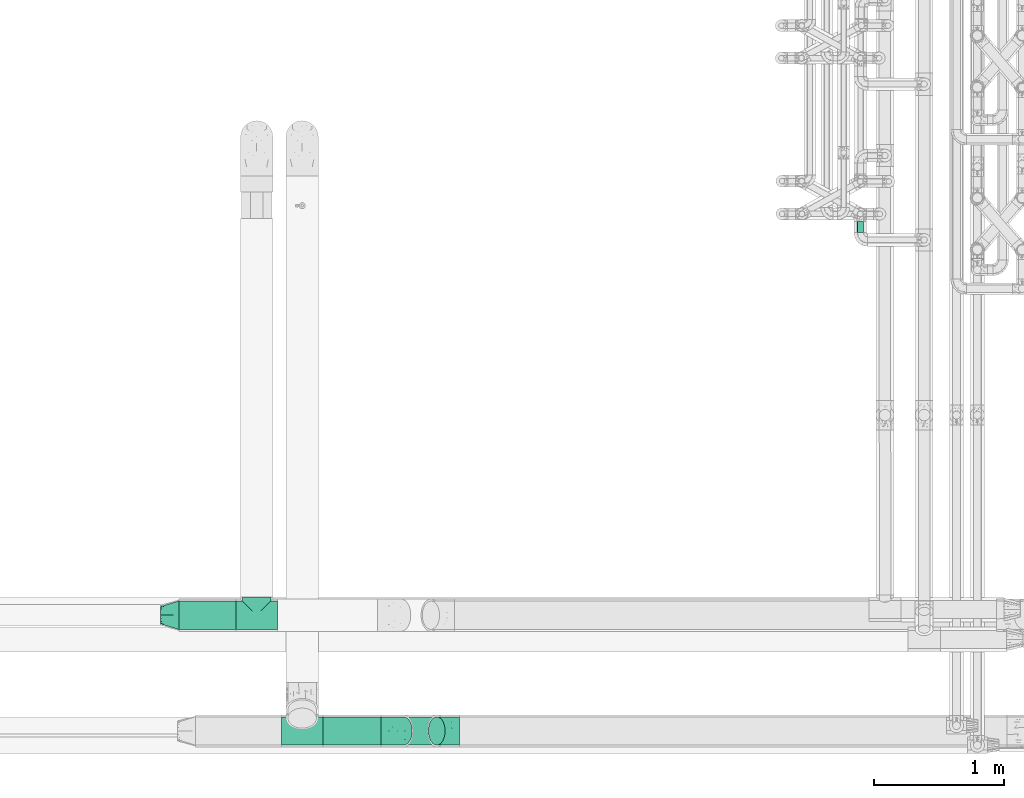
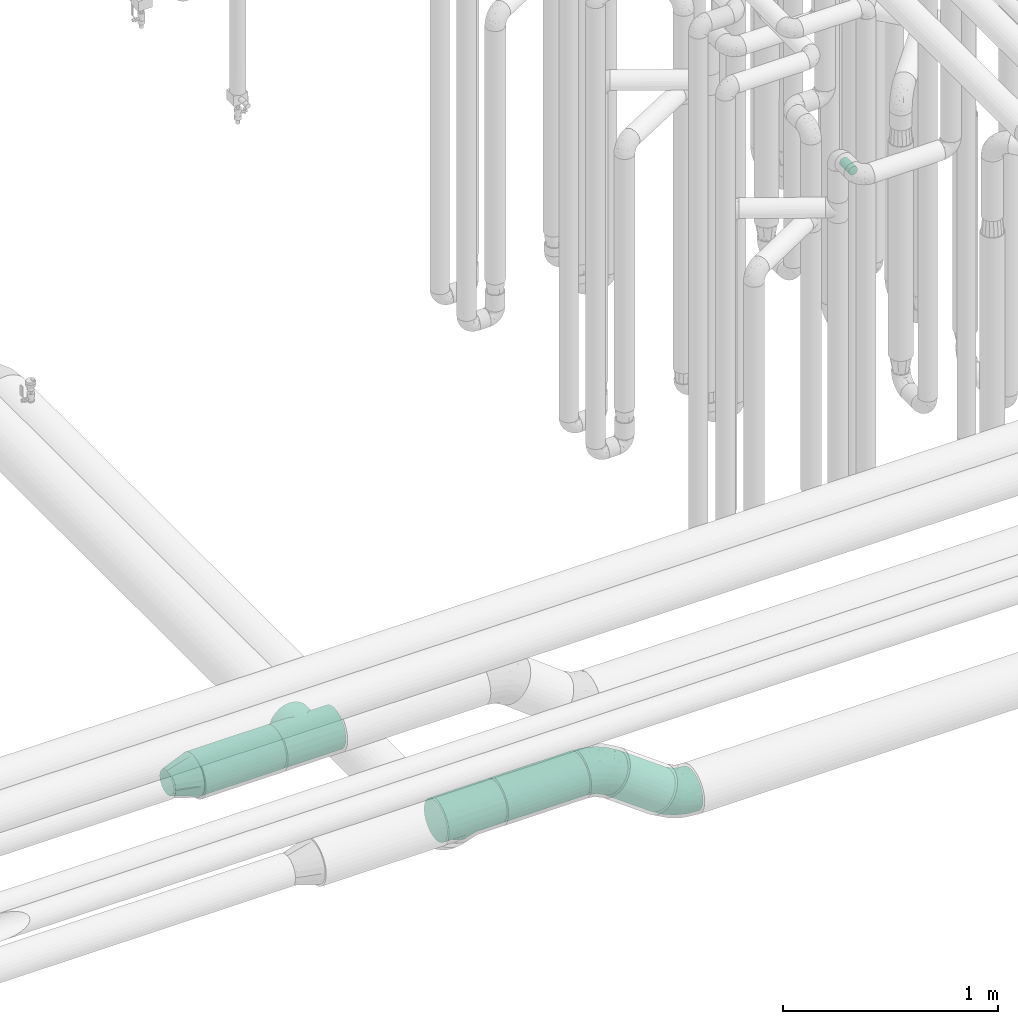
# One storey, part 594 of 824: 5 flow fittings, 4 flow segments.
"""IFC2X3 building model written with IfcOpenShell, lengths in millimetres."""

from ifc_helpers import new_model, entity, si_unit, converted_unit, derived_unit, direction, frame, origin, origin_2d_with_axis, place, context, subcontext, project, spatial, circle, extrude, faceted_brep, source, transform, mapped, material, type_object, type_shapes, element, save


model = new_model("IFC2X3")

# Units and contexts
model_context = context("Model", 3, precision=0.01, world=origin(), true_north=direction((6.12303176911189e-17, 1.0)))
body_context = subcontext(model_context, "Body", "Model", "MODEL_VIEW")
ifc_project = project(units=[si_unit("LENGTHUNIT", "METRE", prefix="MILLI"), si_unit("AREAUNIT", "SQUARE_METRE"), si_unit("VOLUMEUNIT", "CUBIC_METRE"), converted_unit("PLANEANGLEUNIT", "DEGREE", entity("IfcRatioMeasure", 0.0174532925199433), si_unit("PLANEANGLEUNIT", "RADIAN"), dimensions=[0, 0, 0, 0, 0, 0, 0]), si_unit("MASSUNIT", "GRAM", prefix="KILO"), derived_unit("MASSDENSITYUNIT", [(si_unit("MASSUNIT", "GRAM", prefix="KILO"), 1), (si_unit("LENGTHUNIT", "METRE"), -3)]), derived_unit("MOMENTOFINERTIAUNIT", [(si_unit("LENGTHUNIT", "METRE"), 4)]), si_unit("TIMEUNIT", "SECOND"), si_unit("FREQUENCYUNIT", "HERTZ"), si_unit("THERMODYNAMICTEMPERATUREUNIT", "DEGREE_CELSIUS"), derived_unit("THERMALTRANSMITTANCEUNIT", [(si_unit("MASSUNIT", "GRAM", prefix="KILO"), 1), (si_unit("THERMODYNAMICTEMPERATUREUNIT", "KELVIN"), -1), (si_unit("TIMEUNIT", "SECOND"), -3)]), derived_unit("VOLUMETRICFLOWRATEUNIT", [(si_unit("LENGTHUNIT", "METRE"), 3), (si_unit("TIMEUNIT", "SECOND"), -1)]), derived_unit("MASSFLOWRATEUNIT", [(si_unit("MASSUNIT", "GRAM", prefix="KILO"), 1), (si_unit("TIMEUNIT", "SECOND"), -1)]), derived_unit("ROTATIONALFREQUENCYUNIT", [(si_unit("TIMEUNIT", "SECOND"), -1)]), si_unit("ELECTRICCURRENTUNIT", "AMPERE"), si_unit("ELECTRICVOLTAGEUNIT", "VOLT"), si_unit("POWERUNIT", "WATT"), si_unit("FORCEUNIT", "NEWTON", prefix="KILO"), si_unit("ILLUMINANCEUNIT", "LUX"), si_unit("LUMINOUSFLUXUNIT", "LUMEN"), si_unit("LUMINOUSINTENSITYUNIT", "CANDELA"), derived_unit("USERDEFINED", [(si_unit("MASSUNIT", "GRAM", prefix="KILO"), -1), (si_unit("LENGTHUNIT", "METRE"), -2), (si_unit("TIMEUNIT", "SECOND"), 3), (si_unit("LUMINOUSFLUXUNIT", "LUMEN"), 1)]), derived_unit("LINEARVELOCITYUNIT", [(si_unit("LENGTHUNIT", "METRE"), 1), (si_unit("TIMEUNIT", "SECOND"), -1)]), si_unit("PRESSUREUNIT", "PASCAL"), derived_unit("USERDEFINED", [(si_unit("LENGTHUNIT", "METRE"), -2), (si_unit("MASSUNIT", "GRAM", prefix="KILO"), 1), (si_unit("TIMEUNIT", "SECOND"), -2)]), derived_unit("LINEARFORCEUNIT", [(si_unit("MASSUNIT", "GRAM", prefix="KILO"), 1), (si_unit("LENGTHUNIT", "METRE"), 1), (si_unit("TIMEUNIT", "SECOND"), -2), (si_unit("LENGTHUNIT", "METRE"), -1)]), derived_unit("PLANARFORCEUNIT", [(si_unit("MASSUNIT", "GRAM", prefix="KILO"), 1), (si_unit("LENGTHUNIT", "METRE"), 1), (si_unit("TIMEUNIT", "SECOND"), -2), (si_unit("LENGTHUNIT", "METRE"), -2)])], contexts=[model_context])

# Site, building, storey
site_placement = place(None, origin())
site = spatial("IfcSite", under=ifc_project, at=site_placement, CompositionType="ELEMENT")
building_placement = place(site_placement, origin())
building = spatial("IfcBuilding", under=site, at=building_placement, CompositionType="ELEMENT")
storey_placement = place(building_placement, frame((0.0, 0.0, 28200.0)))
storey = spatial("IfcBuildingStorey", under=building, at=storey_placement, CompositionType="ELEMENT", Elevation=28200.0)

# Flow segments
pipe_segment_type_1 = type_object("IfcPipeSegmentType", PredefinedType="NOTDEFINED")
flow_segment_1_placement = place(storey_placement, frame((30479.76, 7155.11, 2688.9)))
element("IfcFlowSegment", 1, at=flow_segment_1_placement, inside=storey, type_object=pipe_segment_type_1, context=body_context, shape_type="SweptSolid", body=[
    extrude(circle(Radius=109.5, at=origin_2d_with_axis()), frame((0.0, 111.1, 111.1), z_axis=(1.0, 0.0, 0.0), x_axis=(0.0, 1.0, 0.0)), (0.0, 0.0, 1.0), 440.240643085185),
])
flow_segment_2_placement = place(storey_placement, frame((31590.0, 6263.9, 2688.9)))
element("IfcFlowSegment", 2, at=flow_segment_2_placement, inside=storey, type_object=pipe_segment_type_1, context=body_context, shape_type="SweptSolid", body=[
    extrude(circle(Radius=109.5, at=origin_2d_with_axis()), frame((0.0, 111.1, 111.1), z_axis=(1.0, 0.0, 0.0), x_axis=(0.0, -1.0, 0.0)), (0.0, 0.0, 1.0), 446.080617390534),
])
flow_segment_3_placement = place(storey_placement, frame((32146.69, 6263.9, 2467.48)))
element("IfcFlowSegment", 3, at=flow_segment_3_placement, inside=storey, type_object=pipe_segment_type_1, context=body_context, shape_type="SweptSolid", body=[
    extrude(circle(Radius=109.5, at=origin_2d_with_axis()), frame((319.73, 111.1, 90.08), z_axis=(-0.80811788469918, 0.0, 0.589020784378041), x_axis=(0.0, -1.0, 0.0)), (0.0, 0.0, 1.0), 313.861133125843),
])
pipe_segment_type_2 = type_object("IfcPipeSegmentType", PredefinedType="NOTDEFINED")
flow_segment_4_placement = place(storey_placement, frame((35702.45, 10213.2, 2574.4)))
element("IfcFlowSegment", 4, at=flow_segment_4_placement, inside=storey, type_object=pipe_segment_type_2, context=body_context, shape_type="SweptSolid", body=[
    extrude(circle(Radius=24.0, at=origin_2d_with_axis()), frame((25.6, 0.0, 25.6), z_axis=(0.0, 1.0, 0.0), x_axis=(-1.0, 0.0, 0.0)), (0.0, 0.0, 1.0), 85.9654132835041),
])

# Flow fittings
ifc_material = material()
pipe_fitting_type_1 = type_object("IfcPipeFittingType", PredefinedType="NOTDEFINED", material=ifc_material)
shared_shape_1 = source(origin(), body_context, "Body", "Brep", [
    faceted_brep([(-160.0, 0.0, -109.5), (-160.0, -28.34, -105.77), (-160.0, -54.75, -94.83), (-160.0, -66.09, -86.13), (-160.0, -77.43, -77.43), (-160.0, -86.13, -66.09), (-160.0, -94.83, -54.75), (-160.0, -100.3, -41.55), (-160.0, -103.03, -34.94), (-160.0, -105.77, -28.34), (-160.0, -106.7, -21.26), (-160.0, -107.63, -14.17), (-160.0, -109.5, 0.0), (-160.0, -107.63, 14.17), (-160.0, -106.7, 21.26), (-160.0, -105.77, 28.34), (-160.0, -103.03, 34.94), (-160.0, -100.3, 41.55), (-160.0, -94.83, 54.75), (-160.0, -86.13, 66.09), (-160.0, -77.43, 77.43), (-160.0, -66.09, 86.13), (-160.0, -54.75, 94.83), (-160.0, -28.34, 105.77), (-160.0, 0.0, 109.5), (-160.0, 28.34, 105.77), (-160.0, 54.75, 94.83), (-160.0, 77.43, 77.43), (-160.0, 94.83, 54.75), (-160.0, 105.77, 28.34), (-160.0, 109.5, 0.0), (-160.0, 105.77, -28.34), (-160.0, 94.83, -54.75), (-160.0, 77.43, -77.43), (-160.0, 54.75, -94.83), (-160.0, 28.34, -105.77), (160.0, 28.34, -105.77), (160.0, 54.75, -94.83), (160.0, 77.43, -77.43), (160.0, 94.83, -54.75), (160.0, 105.77, -28.34), (160.0, 109.5, 0.0), (160.0, 105.77, 28.34), (160.0, 94.83, 54.75), (160.0, 77.43, 77.43), (160.0, 54.75, 94.83), (160.0, 28.34, 105.77), (160.0, 0.0, 109.5), (160.0, -28.34, 105.77), (160.0, -54.75, 94.83), (160.0, -66.09, 86.13), (160.0, -77.43, 77.43), (160.0, -86.13, 66.09), (160.0, -94.83, 54.75), (160.0, -100.3, 41.55), (160.0, -103.03, 34.94), (160.0, -105.77, 28.34), (160.0, -106.7, 21.26), (160.0, -107.63, 14.17), (160.0, -109.5, 0.0), (160.0, -107.63, -14.17), (160.0, -106.7, -21.26), (160.0, -105.77, -28.34), (160.0, -103.03, -34.94), (160.0, -100.3, -41.55), (160.0, -94.83, -54.75), (160.0, -86.13, -66.09), (160.0, -77.43, -77.43), (160.0, -66.09, -86.13), (160.0, -54.75, -94.83), (160.0, -28.34, -105.77), (160.0, 0.0, -109.5), (107.07, -107.07, 22.92), (108.29, -108.29, 11.46), (103.67, -103.67, 33.47), (100.26, -100.26, 44.01), (77.6, -77.6, 77.26), (63.52, -63.52, 89.2), (90.1, -90.1, 62.22), (95.18, -95.18, 53.12), (-100.26, -100.26, 44.01), (-103.67, -103.67, 33.47), (-108.29, -108.29, 11.46), (-107.07, -107.07, 22.92), (-109.5, -109.5, 0.0), (109.5, -109.5, 0.0), (-63.52, -63.52, 89.2), (-77.6, -77.6, 77.26), (-90.1, -90.1, 62.22), (-48.39, -48.39, 98.23), (-95.18, -95.18, 53.12), (48.39, -48.39, 98.23), (16.39, -16.39, 108.27), (32.59, -32.59, 104.54), (0.0, 0.0, 109.5), (-16.39, -16.39, 108.27), (-32.59, -32.59, 104.54), (0.0, 0.0, -109.5), (16.39, -16.39, -108.27), (-108.29, -108.29, -11.46), (108.29, -108.29, -11.46), (-16.39, -16.39, -108.27), (32.59, -32.59, -104.54), (-90.1, -90.1, -62.22), (63.52, -63.52, -89.2), (-103.67, -103.67, -33.47), (-100.26, -100.26, -44.01), (-77.6, -77.6, -77.26), (-63.52, -63.52, -89.2), (-32.59, -32.59, -104.54), (-48.39, -48.39, -98.23), (48.39, -48.39, -98.23), (77.6, -77.6, -77.26), (107.07, -107.07, -22.92), (103.67, -103.67, -33.47), (-95.18, -95.18, -53.12), (90.1, -90.1, -62.22), (100.26, -100.26, -44.01), (-107.07, -107.07, -22.92), (95.18, -95.18, -53.12), (0.0, -140.0, -109.5), (28.34, -140.0, -105.77), (54.75, -140.0, -94.83), (77.43, -140.0, -77.43), (94.83, -140.0, -54.75), (100.3, -140.0, -41.55), (105.77, -140.0, -28.34), (107.63, -140.0, -14.17), (109.5, -140.0, 0.0), (107.63, -140.0, 14.17), (105.77, -140.0, 28.34), (100.3, -140.0, 41.55), (94.83, -140.0, 54.75), (77.43, -140.0, 77.43), (54.75, -140.0, 94.83), (28.34, -140.0, 105.77), (0.0, -140.0, 109.5), (-28.34, -140.0, 105.77), (-54.75, -140.0, 94.83), (-77.43, -140.0, 77.43), (-94.83, -140.0, 54.75), (-100.3, -140.0, 41.55), (-105.77, -140.0, 28.34), (-107.63, -140.0, 14.17), (-109.5, -140.0, 0.0), (-107.63, -140.0, -14.17), (-105.77, -140.0, -28.34), (-100.3, -140.0, -41.55), (-94.83, -140.0, -54.75), (-77.43, -140.0, -77.43), (-54.75, -140.0, -94.83), (-28.34, -140.0, -105.77)], [[[0, 1, 2, 3, 4, 5, 6, 7, 8, 9, 10, 11, 12, 13, 14, 15, 16, 17, 18, 19, 20, 21, 22, 23, 24, 25, 26, 27, 28, 29, 30, 31, 32, 33, 34, 35]], [[36, 37, 38, 39, 40, 41, 42, 43, 44, 45, 46, 47, 48, 49, 50, 51, 52, 53, 54, 55, 56, 57, 58, 59, 60, 61, 62, 63, 64, 65, 66, 67, 68, 69, 70, 71]], [[57, 56, 72, 58]], [[58, 72, 73]], [[59, 58, 73]], [[74, 72, 56]], [[54, 53, 75]], [[52, 51, 76]], [[77, 50, 49]], [[74, 54, 75]], [[78, 52, 76]], [[76, 51, 50]], [[76, 50, 77]], [[53, 78, 79, 75]], [[54, 74, 56, 55]], [[80, 17, 81]], [[12, 82, 13]], [[13, 82, 83]], [[82, 12, 84]], [[59, 73, 85]], [[81, 17, 16, 15]], [[83, 15, 14, 13]], [[78, 53, 52]], [[86, 21, 87]], [[87, 20, 19]], [[88, 19, 18]], [[87, 21, 20]], [[22, 86, 89]], [[88, 18, 80, 90]], [[77, 49, 91]], [[48, 47, 92]], [[93, 91, 48]], [[92, 93, 48]], [[87, 19, 88]], [[92, 47, 94]], [[95, 94, 24]], [[48, 91, 49]], [[28, 27, 44, 43]], [[29, 28, 43, 42]], [[26, 25, 46, 45]], [[27, 26, 45, 44]], [[46, 25, 24, 94, 47]], [[30, 29, 42, 41]], [[80, 18, 17]], [[15, 83, 81]], [[96, 95, 23]], [[96, 23, 89]], [[23, 95, 24]], [[89, 23, 22]], [[86, 22, 21]], [[38, 33, 32, 39]], [[40, 31, 30, 41]], [[40, 39, 32, 31]], [[34, 33, 38, 37]], [[97, 0, 35, 36, 71]], [[98, 71, 70]], [[12, 99, 84]], [[59, 85, 100]], [[98, 97, 71]], [[0, 97, 101]], [[102, 98, 70]], [[103, 6, 5]], [[104, 69, 68]], [[37, 36, 35, 34]], [[105, 7, 106]], [[107, 3, 108]], [[109, 110, 1]], [[101, 109, 1]], [[0, 101, 1]], [[110, 2, 1]], [[102, 70, 111]], [[67, 112, 68]], [[62, 113, 114]], [[104, 68, 112]], [[112, 67, 66]], [[6, 103, 115, 106]], [[66, 65, 116]], [[69, 104, 111]], [[63, 62, 114, 64]], [[117, 64, 114]], [[113, 60, 100]], [[118, 11, 10, 9]], [[65, 117, 119, 116]], [[11, 118, 99]], [[117, 65, 64]], [[113, 62, 61, 60]], [[107, 4, 3]], [[108, 2, 110]], [[108, 3, 2]], [[107, 103, 5]], [[107, 5, 4]], [[112, 66, 116]], [[7, 105, 9, 8]], [[12, 11, 99]], [[105, 118, 9]], [[106, 7, 6]], [[59, 100, 60]], [[69, 111, 70]], [[120, 121, 122, 123, 124, 125, 126, 127, 128, 129, 130, 131, 132, 133, 134, 135, 136, 137, 138, 139, 140, 141, 142, 143, 144, 145, 146, 147, 148, 149, 150, 151]], [[143, 142, 83]], [[144, 82, 84]], [[144, 143, 82]], [[142, 80, 81, 83]], [[139, 138, 86]], [[88, 140, 139]], [[80, 142, 141, 140]], [[89, 138, 137]], [[143, 83, 82]], [[140, 88, 90, 80]], [[86, 87, 139]], [[88, 139, 87]], [[96, 89, 137]], [[136, 94, 95]], [[96, 137, 95]], [[86, 138, 89]], [[75, 132, 131, 130]], [[95, 137, 136]], [[134, 91, 135]], [[135, 92, 136]], [[77, 134, 133]], [[128, 85, 73]], [[133, 132, 78]], [[73, 72, 129]], [[77, 91, 134]], [[93, 92, 135]], [[91, 93, 135]], [[130, 72, 74, 75]], [[72, 130, 129]], [[78, 76, 133]], [[128, 73, 129]], [[132, 75, 79, 78]], [[77, 133, 76]], [[136, 92, 94]], [[127, 126, 113]], [[117, 126, 125, 124]], [[128, 127, 100]], [[126, 117, 114, 113]], [[123, 122, 104]], [[118, 146, 145]], [[128, 100, 85]], [[123, 116, 124]], [[111, 122, 121]], [[124, 116, 119, 117]], [[104, 112, 123]], [[116, 123, 112]], [[102, 111, 121]], [[120, 97, 98]], [[102, 121, 98]], [[104, 122, 111]], [[127, 113, 100]], [[98, 121, 120]], [[150, 110, 151]], [[151, 101, 120]], [[108, 150, 149]], [[144, 84, 99]], [[149, 148, 103]], [[146, 106, 148, 147]], [[99, 118, 145]], [[108, 110, 150]], [[109, 101, 151]], [[110, 109, 151]], [[146, 118, 105, 106]], [[144, 99, 145]], [[103, 107, 149]], [[148, 106, 115, 103]], [[108, 149, 107]], [[120, 101, 97]]]),
])
type_shapes(pipe_fitting_type_1, [shared_shape_1])
for number, where, z_axis, x_axis in (
    (5, (31080.0, 7266.2, 2800.0), (2.63361265060741e-05, 0.0, 1.0), (-1.0, 0.0, 2.63361265060741e-05)),
    (6, (31430.0, 6375.0, 2800.0), (0.0, 0.707106781186543, 0.707106781186552), (-1.0, 0.0, 0.0)),
):
    element("IfcFlowFitting", number, at=place(storey_placement, frame(where, z_axis=z_axis, x_axis=x_axis)), inside=storey, type_object=pipe_fitting_type_1, material=ifc_material, context=body_context, shape_type="MappedRepresentation", body=[
        mapped(shared_shape_1, transform((0.0, 0.0, 0.0), scale=1.0)),
    ])
pipe_fitting_type_2 = type_object("IfcPipeFittingType", PredefinedType="NOTDEFINED", material=ifc_material)
shared_shape_2 = source(origin(), body_context, "Body", "Brep", [
    faceted_brep([(140.0, -36.24, 54.23), (140.0, -47.02, 47.02), (140.0, -54.23, 36.24), (140.0, -61.44, 25.45), (140.0, -63.97, 12.72), (140.0, -66.5, 0.0), (140.0, -63.97, -12.72), (140.0, -61.44, -25.45), (140.0, -54.23, -36.24), (140.0, -47.02, -47.02), (140.0, -36.24, -54.23), (140.0, -25.45, -61.44), (140.0, -12.72, -63.97), (140.0, 0.0, -66.5), (140.0, 12.72, -63.97), (140.0, 25.45, -61.44), (140.0, 36.24, -54.23), (140.0, 47.02, -47.02), (140.0, 54.23, -36.24), (140.0, 61.44, -25.45), (140.0, 63.97, -12.72), (140.0, 66.5, 0.0), (140.0, 63.97, 12.72), (140.0, 61.44, 25.45), (140.0, 54.23, 36.24), (140.0, 47.02, 47.02), (140.0, 36.24, 54.23), (140.0, 25.45, 61.44), (140.0, 12.72, 63.97), (140.0, 0.0, 66.5), (140.0, -12.72, 63.97), (140.0, -25.45, 61.44), (0.0, 0.0, 109.5), (0.0, 33.84, 104.14), (0.0, 64.36, 88.59), (0.0, 88.59, 64.36), (0.0, 104.14, 33.84), (0.0, 109.5, 0.0), (0.0, 104.14, -33.84), (0.0, 88.59, -64.36), (0.0, 64.36, -88.59), (0.0, 33.84, -104.14), (0.0, 0.0, -109.5), (0.0, -33.84, -104.14), (0.0, -64.36, -88.59), (0.0, -88.59, -64.36), (0.0, -104.14, -33.84), (0.0, -109.5, 0.0), (0.0, -104.14, 33.84), (0.0, -88.59, 64.36), (0.0, -64.36, 88.59), (0.0, -33.84, 104.14)], [[[0, 1, 2, 3, 4, 5, 6, 7, 8, 9, 10, 11, 12, 13, 14, 15, 16, 17, 18, 19, 20, 21, 22, 23, 24, 25, 26, 27, 28, 29, 30, 31]], [[32, 33, 34, 35, 36, 37, 38, 39, 40, 41, 42, 43, 44, 45, 46, 47, 48, 49, 50, 51]], [[37, 20, 38]], [[16, 15, 40, 17]], [[11, 44, 43]], [[14, 13, 42]], [[39, 19, 18, 17]], [[42, 41, 14]], [[17, 40, 39]], [[12, 42, 13]], [[15, 41, 40]], [[10, 9, 44, 11]], [[42, 12, 43]], [[41, 15, 14]], [[8, 7, 45, 9]], [[6, 5, 47]], [[19, 39, 38]], [[46, 7, 6]], [[20, 19, 38]], [[45, 7, 46]], [[6, 47, 46]], [[20, 37, 21]], [[44, 9, 45]], [[12, 11, 43]], [[47, 4, 48]], [[0, 31, 50, 1]], [[27, 34, 33]], [[30, 29, 32]], [[49, 3, 2, 1]], [[32, 51, 30]], [[1, 50, 49]], [[28, 32, 29]], [[31, 51, 50]], [[26, 25, 34, 27]], [[32, 28, 33]], [[51, 31, 30]], [[24, 23, 35, 25]], [[22, 21, 37]], [[3, 49, 48]], [[36, 23, 22]], [[4, 3, 48]], [[35, 23, 36]], [[22, 37, 36]], [[4, 47, 5]], [[34, 25, 35]], [[28, 27, 33]]]),
])
type_shapes(pipe_fitting_type_2, [shared_shape_2])
flow_fitting_placement = place(storey_placement, frame((30479.76, 7266.2, 2800.0), z_axis=(2.62756642280567e-06, 0.0, 1.0), x_axis=(-1.0, 0.0, 2.62756642280567e-06)))
element("IfcFlowFitting", 7, at=flow_fitting_placement, inside=storey, type_object=pipe_fitting_type_2, material=ifc_material, context=body_context, shape_type="MappedRepresentation", body=[
    mapped(shared_shape_2, transform((0.0, 0.0, 0.0), scale=1.0)),
])
pipe_fitting_type_3 = type_object("IfcPipeFittingType", PredefinedType="NOTDEFINED", material=ifc_material)
shared_shape_3 = source(origin(), body_context, "Body", "Brep", [
    faceted_brep([(-97.73, 28.34, -105.77), (-97.73, 0.0, -109.5), (-97.73, -28.34, -105.77), (-97.73, -54.75, -94.83), (-97.73, -77.43, -77.43), (-97.73, -94.83, -54.75), (-97.73, -105.77, -28.34), (-97.73, -109.5, 0.0), (-97.73, -105.77, 28.34), (-97.73, -94.83, 54.75), (-97.73, -77.43, 77.43), (-97.73, -54.75, 94.83), (-97.73, -28.34, 105.77), (-97.73, 0.0, 109.5), (-97.73, 28.34, 105.77), (-97.73, 54.75, 94.83), (-97.73, 77.43, 77.43), (-97.73, 94.83, 54.75), (-97.73, 105.77, 28.34), (-97.73, 109.5, 0.0), (-97.73, 105.77, -28.34), (-97.73, 94.83, -54.75), (-97.73, 77.43, -77.43), (-97.73, 54.75, -94.83), (78.98, 57.56, -109.5), (62.28, 80.47, -105.77), (46.73, 101.81, -94.83), (33.37, 120.14, -77.43), (23.12, 134.2, -54.75), (16.68, 143.04, -28.34), (14.48, 146.05, 0.0), (16.68, 143.04, 28.34), (23.12, 134.2, 54.75), (33.37, 120.14, 77.43), (46.73, 101.81, 94.83), (62.28, 80.47, 105.77), (78.98, 57.56, 109.5), (95.67, 34.66, 105.77), (111.23, 13.32, 94.83), (124.58, -5.01, 77.43), (134.83, -19.07, 54.75), (141.28, -27.91, 28.34), (143.47, -30.92, 0.0), (141.28, -27.91, -28.34), (134.83, -19.07, -54.75), (124.58, -5.01, -77.43), (111.23, 13.32, -94.83), (95.67, 34.66, -105.77), (-33.51, -104.43, 0.0), (-4.51, -94.23, 30.73), (22.67, -69.59, 64.21), (-43.87, -83.93, 65.58), (-39.61, -94.44, 47.42), (29.11, -89.36, 0.0), (88.6, -64.65, 0.0), (59.61, -76.25, 19.08), (-51.56, -39.87, 100.71), (-19.38, -59.78, 85.66), (8.96, -27.5, 100.08), (-25.59, -7.83, 108.3), (-8.48, 26.03, 108.86), (65.15, -1.85, 100.71), (-32.67, 48.47, 101.86), (-24.92, 76.51, 88.16), (72.38, -64.12, 40.08), (84.88, -41.99, 65.58), (-36.84, 94.59, 68.09), (-35.92, 110.26, 43.59), (-38.05, 116.81, 21.68), (58.17, -33.41, 85.78), (14.11, 53.39, 105.53), (39.59, 15.66, 108.36), (-58.03, 113.68, 0.0), (-20.07, 126.05, 0.0), (-2.15, 58.42, -101.86), (-42.85, 34.84, -105.53), (-24.92, 76.51, -88.16), (-39.61, -94.44, -47.42), (-38.05, 116.81, -21.68), (-35.92, 110.26, -43.59), (8.96, -27.5, -100.08), (50.87, -36.9, -85.66), (-27.33, -61.26, -85.78), (-25.95, 98.14, -68.09), (-8.48, 26.03, -108.86), (25.29, 8.74, -108.3), (-41.22, -10.66, -108.36), (-4.51, -94.23, -30.73), (-43.87, -83.93, -65.58), (-51.56, -39.87, -100.71), (22.67, -69.59, -64.21), (59.61, -76.25, -19.08), (72.38, -64.12, -40.08), (65.15, -1.85, -100.71), (84.88, -41.99, -65.58)], [[[0, 1, 2, 3, 4, 5, 6, 7, 8, 9, 10, 11, 12, 13, 14, 15, 16, 17, 18, 19, 20, 21, 22, 23]], [[24, 25, 26, 27, 28, 29, 30, 31, 32, 33, 34, 35, 36, 37, 38, 39, 40, 41, 42, 43, 44, 45, 46, 47]], [[48, 49, 8]], [[48, 8, 7]], [[50, 51, 52]], [[53, 54, 55]], [[56, 57, 58]], [[51, 10, 9]], [[13, 12, 59]], [[12, 11, 56]], [[13, 59, 60]], [[38, 37, 61]], [[52, 51, 9]], [[11, 10, 57]], [[15, 14, 62]], [[16, 15, 63]], [[64, 40, 65]], [[17, 66, 67]], [[14, 13, 60]], [[34, 33, 63]], [[51, 57, 10]], [[67, 68, 18]], [[40, 39, 65]], [[19, 18, 68]], [[18, 17, 67]], [[50, 65, 69]], [[63, 15, 62]], [[49, 53, 55]], [[48, 53, 49]], [[35, 70, 36]], [[38, 69, 39]], [[60, 71, 36]], [[16, 63, 66]], [[60, 59, 71]], [[64, 55, 41]], [[71, 37, 36]], [[41, 55, 54]], [[49, 64, 50]], [[69, 38, 61]], [[57, 69, 58]], [[50, 69, 57]], [[54, 42, 41]], [[49, 55, 64]], [[33, 66, 63]], [[17, 16, 66]], [[72, 68, 73]], [[8, 49, 52]], [[73, 68, 30]], [[58, 61, 71]], [[68, 31, 30]], [[14, 60, 62]], [[67, 66, 32]], [[68, 72, 19]], [[32, 66, 33]], [[31, 68, 67]], [[34, 62, 70]], [[62, 34, 63]], [[32, 31, 67]], [[70, 62, 60]], [[40, 64, 41]], [[58, 71, 59]], [[56, 59, 12]], [[57, 51, 50]], [[8, 52, 9]], [[50, 52, 49]], [[69, 65, 39]], [[64, 65, 50]], [[57, 56, 11]], [[59, 56, 58]], [[71, 61, 37]], [[69, 61, 58]], [[36, 70, 60]], [[34, 70, 35]], [[23, 74, 75]], [[23, 76, 74]], [[77, 6, 5]], [[22, 76, 23]], [[72, 78, 19]], [[78, 20, 19]], [[79, 21, 20]], [[80, 81, 82]], [[83, 22, 21]], [[84, 85, 86]], [[26, 25, 74]], [[1, 0, 75]], [[6, 87, 48]], [[84, 86, 1]], [[48, 7, 6]], [[82, 88, 4]], [[5, 88, 77]], [[80, 86, 85]], [[89, 3, 2]], [[90, 88, 82]], [[5, 4, 88]], [[4, 3, 82]], [[1, 86, 2]], [[28, 27, 83]], [[43, 91, 92]], [[93, 85, 47]], [[78, 72, 73]], [[87, 91, 53]], [[30, 29, 78]], [[94, 81, 45]], [[79, 29, 28]], [[44, 43, 92]], [[46, 45, 81]], [[79, 28, 83]], [[26, 74, 76]], [[94, 92, 90]], [[84, 25, 24]], [[90, 92, 87]], [[79, 83, 21]], [[26, 76, 27]], [[80, 89, 86]], [[84, 24, 85]], [[81, 80, 93]], [[22, 83, 76]], [[24, 47, 85]], [[87, 92, 91]], [[44, 94, 45]], [[47, 46, 93]], [[54, 53, 91]], [[75, 74, 84]], [[42, 54, 43]], [[20, 78, 79]], [[25, 84, 74]], [[48, 87, 53]], [[27, 76, 83]], [[91, 43, 54]], [[82, 3, 89]], [[78, 29, 79]], [[90, 82, 81]], [[78, 73, 30]], [[77, 90, 87]], [[90, 77, 88]], [[6, 77, 87]], [[92, 94, 44]], [[81, 94, 90]], [[86, 89, 2]], [[82, 89, 80]], [[81, 93, 46]], [[85, 93, 80]], [[1, 75, 84]], [[23, 75, 0]]]),
])
type_shapes(pipe_fitting_type_3, [shared_shape_3])
for number, where, z_axis, x_axis in (
    (8, (32133.81, 6375.0, 2800.0), (0.0, 1.0, 0.0), (1.0, 0.0, 0.0)),
    (9, (32545.4, 6375.0, 2500.0), (0.0, -1.0, 0.0), (0.8081178846992, 0.0, -0.589020784378014)),
):
    element("IfcFlowFitting", number, at=place(storey_placement, frame(where, z_axis=z_axis, x_axis=x_axis)), inside=storey, type_object=pipe_fitting_type_3, material=ifc_material, context=body_context, shape_type="MappedRepresentation", body=[
        mapped(shared_shape_3, transform((0.0, 0.0, 0.0), scale=1.0)),
    ])

save(model, "model.ifc")
